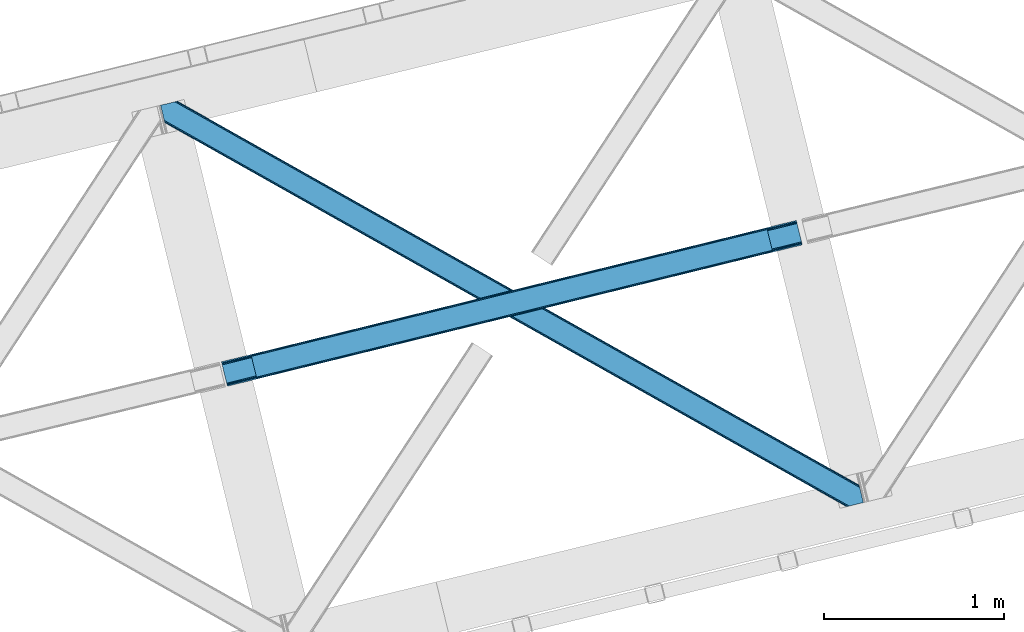
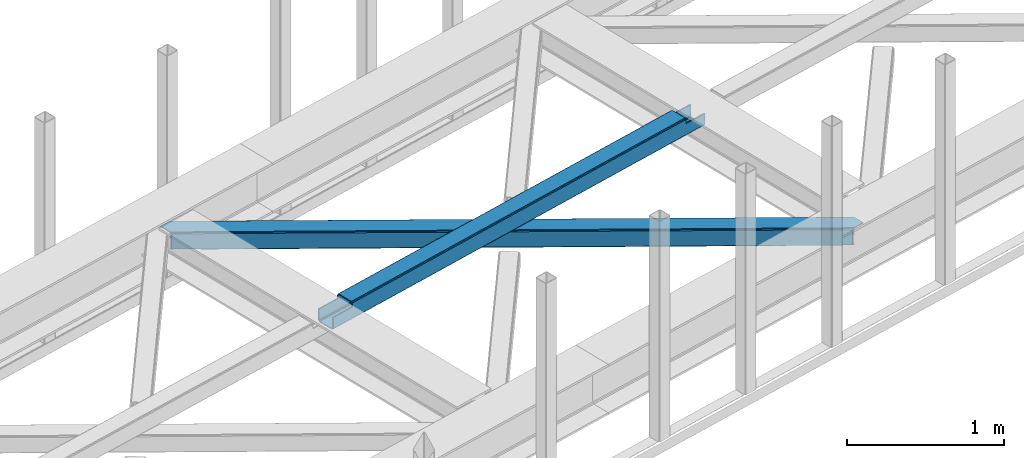
# One storey, part 30 of 67: 1 beam, 1 member.
"""IFC4 building model written with IfcOpenShell, lengths in millimetres."""

import ifcopenshell
import ifcopenshell.guid

model = None  # the IFC model being written
_history = None  # IfcOwnerHistory: only IFC2X3 demands one
_inside = {}  # id of a spatial element -> (the spatial element, [elements in it])
_under = {}  # id of a project, library or spatial element -> (it, [spatial elements below it])
_declared = {}  # id of a project -> (the project, [libraries it declares])
_typed = {}  # id of a type object -> (the type object, [elements of that type])
_made_of = {}  # id of a material, layer set ... -> (it, [elements and type objects made of it])


def new_model(schema):
    """Start an empty IFC model of exactly this schema.

    Asked for "IFC4X3", IfcOpenShell would pick the latest addendum, in which some entities
    have other attributes; the version numbers below select the first issue.
    IFC2X3 requires an IfcOwnerHistory on every rooted entity: one is made here for all.
    """
    global model, _history
    if schema == "IFC4X3":
        model = ifcopenshell.file(schema_version=(4, 3, 0, 0))
    else:
        model = ifcopenshell.file(schema=schema)
    _inside.clear()
    _under.clear()
    _declared.clear()
    _typed.clear()
    _made_of.clear()
    _history = None
    if model.schema == "IFC2X3":
        org = make("IfcOrganization", Name="unknown")
        user = make(
            "IfcPersonAndOrganization",
            ThePerson=make("IfcPerson", FamilyName="unknown"),
            TheOrganization=org,
        )
        app = make(
            "IfcApplication",
            ApplicationDeveloper=org,
            Version="unknown",
            ApplicationFullName="unknown",
            ApplicationIdentifier="unknown",
        )
        _history = make(
            "IfcOwnerHistory",
            OwningUser=user,
            OwningApplication=app,
            ChangeAction="ADDED",
            CreationDate=0,
        )
    return model


def make(cls, **values):
    """One entity of the class cls with the attributes given. An attribute that is None is left unset."""
    return model.create_entity(
        cls, **{name: value for name, value in values.items() if value is not None}
    )


def entity(cls, *values):
    """Any entity or typed value of the class cls, its attributes in the order of the schema. None: left unset."""
    e = model.create_entity(cls)
    for i, value in enumerate(values):
        if value is not None:
            e[i] = value
    return e


def rooted(cls, **values):
    """An entity with a GlobalId (a new one), such as an element, a storey or a relation."""
    return make(cls, GlobalId=ifcopenshell.guid.new(), OwnerHistory=_history, **values)


def si_unit(unit_type, name, prefix=None):
    """IfcSIUnit, for example si_unit("LENGTHUNIT", "METRE", prefix="MILLI")."""
    return make("IfcSIUnit", UnitType=unit_type, Prefix=prefix, Name=name)


def converted_unit(unit_type, name, factor, base, dimensions=None, offset=None):
    """IfcConversionBasedUnit, such as the inch: factor (a typed value) times the base unit."""
    return make(
        "IfcConversionBasedUnit"
        if offset is None
        else "IfcConversionBasedUnitWithOffset",
        ConversionOffset=offset,
        Dimensions=None
        if dimensions is None
        else entity("IfcDimensionalExponents", *dimensions),
        UnitType=unit_type,
        Name=name,
        ConversionFactor=make(
            "IfcMeasureWithUnit", ValueComponent=factor, UnitComponent=base
        ),
    )


def derived_unit(unit_type, elements):
    """IfcDerivedUnit: a product of units, each with its exponent."""
    return make(
        "IfcDerivedUnit",
        Elements=[
            make("IfcDerivedUnitElement", Unit=unit, Exponent=power)
            for unit, power in elements
        ],
        UnitType=unit_type,
    )


def assignment(units):
    """IfcUnitAssignment: the units of a project."""
    return None if units is None else make("IfcUnitAssignment", Units=units)


def point(xyz):
    """IfcCartesianPoint."""
    return None if xyz is None else make("IfcCartesianPoint", Coordinates=xyz)


def direction(xyz):
    """IfcDirection."""
    return None if xyz is None else make("IfcDirection", DirectionRatios=xyz)


def frame(location, z_axis=None, x_axis=None):
    """IfcAxis2Placement3D, a coordinate frame: its origin and axes. An axis left out is left unset."""
    return make(
        "IfcAxis2Placement3D",
        Location=point(location),
        Axis=direction(z_axis),
        RefDirection=direction(x_axis),
    )


def origin():
    """The frame at (0, 0, 0) with its axes left unset."""
    return frame((0.0, 0.0, 0.0))


def place(relative_to, where):
    """IfcLocalPlacement: puts the frame where relative to a parent placement (None: the world)."""
    return make(
        "IfcLocalPlacement", PlacementRelTo=relative_to, RelativePlacement=where
    )


def context(
    kind, dimensions, precision=None, world=None, true_north=None, identifier=None
):
    """IfcGeometricRepresentationContext, for example the 3D "Model" context."""
    return make(
        "IfcGeometricRepresentationContext",
        ContextIdentifier=identifier,
        ContextType=kind,
        CoordinateSpaceDimension=dimensions,
        Precision=precision,
        WorldCoordinateSystem=world,
        TrueNorth=true_north,
    )


def subcontext(parent, identifier, kind, view, scale=None):
    """IfcGeometricRepresentationSubContext, for example "Body" below "Model"."""
    return make(
        "IfcGeometricRepresentationSubContext",
        ContextIdentifier=identifier,
        ContextType=kind,
        ParentContext=parent,
        TargetScale=scale,
        TargetView=view,
    )


def project(units=None, contexts=None):
    """IfcProject with its units and contexts."""
    return rooted(
        "IfcProject",
        Name="project",
        RepresentationContexts=contexts,
        UnitsInContext=assignment(units),
    )


def spatial(cls, under=None, at=None, **own):
    """A site, building, storey or space (cls), placed at a placement, below another one or the project."""
    s = rooted(cls, ObjectPlacement=at, **own)
    if under is not None:
        _under.setdefault(under.id(), (under, []))[1].append(s)
    return s


def point_list(points):
    """IfcCartesianPointList2D or 3D."""
    cls = (
        "IfcCartesianPointList2D" if len(points[0]) == 2 else "IfcCartesianPointList3D"
    )
    return make(cls, CoordList=points)


def triangles(points, corners, closed=None, point_numbers=None):
    """IfcTriangulatedFaceSet: each triangle names its three corners, points numbered from 1."""
    return make(
        "IfcTriangulatedFaceSet",
        Coordinates=point_list(points),
        Closed=closed,
        CoordIndex=corners,
        PnIndex=point_numbers,
    )


def polygons(points, faces, closed=None, point_numbers=None):
    """IfcPolygonalFaceSet: a face is its outer loop, then its inner loops; points numbered from 1."""
    made = []
    for loops in faces:
        if len(loops) == 1:
            made.append(make("IfcIndexedPolygonalFace", CoordIndex=loops[0]))
        else:
            made.append(
                make(
                    "IfcIndexedPolygonalFaceWithVoids",
                    CoordIndex=loops[0],
                    InnerCoordIndices=loops[1:],
                )
            )
    return make(
        "IfcPolygonalFaceSet",
        Coordinates=point_list(points),
        Closed=closed,
        Faces=made,
        PnIndex=point_numbers,
    )


def shape(context_of_items, identifier, shape_type, items):
    """IfcShapeRepresentation: the items that make up one representation, for example the "Body"."""
    return make(
        "IfcShapeRepresentation",
        ContextOfItems=context_of_items,
        RepresentationIdentifier=identifier,
        RepresentationType=shape_type,
        Items=items,
    )


def material(Name=None, Category=None):
    """IfcMaterial."""
    return make("IfcMaterial", Name=Name, Category=Category)


def made_of(thing, what):
    """Note that an element or type object is made of a material, layer set ...; save() writes the relation."""
    if what is not None:
        _made_of.setdefault(what.id(), (what, []))[1].append(thing)
    return thing


def type_object(cls, material=None, **own):
    """A type object (cls), such as IfcWallType, which elements share."""
    return made_of(rooted(cls, **own), material)


def element(
    cls,
    number,
    at=None,
    inside=None,
    cuts=None,
    type_object=None,
    material=None,
    context=None,
    identifier="Body",
    shape_type=None,
    held_by="IfcProductDefinitionShape",
    body=None,
    shapes=None,
    **own,
):
    """One element of the class cls, such as IfcWall. Its Tag is "e" and its number.

    at: its placement. inside: the storey or other place that contains it. cuts: it is an
    opening in that element (IfcRelVoidsElement). A single representation is given by context,
    identifier, shape_type and body (its items); several are given by shapes. held_by: the class
    of the entity that holds the representations. save() writes the other relations.
    """
    e = rooted(cls, Tag="e%d" % number, ObjectPlacement=at, **own)
    if body is not None:
        shapes = [shape(context, identifier, shape_type, body)]
    if shapes is not None:
        e.Representation = make(held_by, Representations=shapes)
    if inside is not None:
        _inside.setdefault(inside.id(), (inside, []))[1].append(e)
    if cuts is not None:
        rooted(
            "IfcRelVoidsElement", RelatingBuildingElement=cuts, RelatedOpeningElement=e
        )
    if type_object is not None:
        _typed.setdefault(type_object.id(), (type_object, []))[1].append(e)
    return made_of(e, material)


def aggregate(whole, parts):
    """IfcRelAggregates: a whole, such as a stair, and the parts it consists of."""
    return rooted("IfcRelAggregates", RelatingObject=whole, RelatedObjects=parts)


def save(model, path):
    """Write the relations noted so far, then the file.

    IfcRelAggregates (storeys below a building ...), IfcRelContainedInSpatialStructure (elements
    in a storey), IfcRelDefinesByType, IfcRelAssociatesMaterial and IfcRelDeclares: one each for
    every whole, place, type object, material and project.
    """
    for whole, parts in _under.values():
        aggregate(whole, parts)
    for where, things in _inside.values():
        rooted(
            "IfcRelContainedInSpatialStructure",
            RelatedElements=things,
            RelatingStructure=where,
        )
    for kind, things in _typed.values():
        rooted("IfcRelDefinesByType", RelatedObjects=things, RelatingType=kind)
    for what, things in _made_of.values():
        rooted("IfcRelAssociatesMaterial", RelatedObjects=things, RelatingMaterial=what)
    for by, libraries in _declared.values():
        rooted("IfcRelDeclares", RelatingContext=by, RelatedDefinitions=libraries)
    model.write(path)


model = new_model("IFC4")

# Units and contexts
model_context = context("Model", 3, precision=0.01, world=origin(), true_north=direction((6.12303176911189e-17, 1.0)))
plan_context = context("Plan", 3, precision=0.01, world=origin(), true_north=direction((6.12303176911189e-17, 1.0)))
body_context = subcontext(model_context, "Body", "Model", "MODEL_VIEW")
ifc_project = project(units=[si_unit("LENGTHUNIT", "METRE", prefix="MILLI"), si_unit("AREAUNIT", "SQUARE_METRE"), si_unit("VOLUMEUNIT", "CUBIC_METRE"), converted_unit("PLANEANGLEUNIT", "DEGREE", entity("IfcRatioMeasure", 0.0174532925199433), si_unit("PLANEANGLEUNIT", "RADIAN"), dimensions=[0, 0, 0, 0, 0, 0, 0]), si_unit("MASSUNIT", "GRAM", prefix="KILO"), derived_unit("MASSDENSITYUNIT", [(si_unit("MASSUNIT", "GRAM", prefix="KILO"), 1), (si_unit("LENGTHUNIT", "METRE"), -3)]), derived_unit("MOMENTOFINERTIAUNIT", [(si_unit("LENGTHUNIT", "METRE"), 4)]), si_unit("TIMEUNIT", "SECOND"), si_unit("FREQUENCYUNIT", "HERTZ"), si_unit("THERMODYNAMICTEMPERATUREUNIT", "DEGREE_CELSIUS"), derived_unit("THERMALTRANSMITTANCEUNIT", [(si_unit("MASSUNIT", "GRAM", prefix="KILO"), 1), (si_unit("THERMODYNAMICTEMPERATUREUNIT", "KELVIN"), -1), (si_unit("TIMEUNIT", "SECOND"), -3)]), derived_unit("VOLUMETRICFLOWRATEUNIT", [(si_unit("LENGTHUNIT", "METRE"), 3), (si_unit("TIMEUNIT", "SECOND"), -1)]), derived_unit("MASSFLOWRATEUNIT", [(si_unit("MASSUNIT", "GRAM", prefix="KILO"), 1), (si_unit("TIMEUNIT", "SECOND"), -1)]), derived_unit("ROTATIONALFREQUENCYUNIT", [(si_unit("TIMEUNIT", "SECOND"), -1)]), si_unit("ELECTRICCURRENTUNIT", "AMPERE"), si_unit("ELECTRICVOLTAGEUNIT", "VOLT"), si_unit("POWERUNIT", "WATT"), si_unit("FORCEUNIT", "NEWTON", prefix="KILO"), si_unit("ILLUMINANCEUNIT", "LUX"), si_unit("LUMINOUSFLUXUNIT", "LUMEN"), si_unit("LUMINOUSINTENSITYUNIT", "CANDELA"), derived_unit("USERDEFINED", [(si_unit("MASSUNIT", "GRAM", prefix="KILO"), -1), (si_unit("LENGTHUNIT", "METRE"), -2), (si_unit("TIMEUNIT", "SECOND"), 3), (si_unit("LUMINOUSFLUXUNIT", "LUMEN"), 1)]), derived_unit("LINEARVELOCITYUNIT", [(si_unit("LENGTHUNIT", "METRE"), 1), (si_unit("TIMEUNIT", "SECOND"), -1)]), si_unit("PRESSUREUNIT", "PASCAL"), derived_unit("USERDEFINED", [(si_unit("LENGTHUNIT", "METRE"), -2), (si_unit("MASSUNIT", "GRAM", prefix="KILO"), 1), (si_unit("TIMEUNIT", "SECOND"), -2)]), derived_unit("LINEARFORCEUNIT", [(si_unit("MASSUNIT", "GRAM", prefix="KILO"), 1), (si_unit("LENGTHUNIT", "METRE"), 1), (si_unit("TIMEUNIT", "SECOND"), -2), (si_unit("LENGTHUNIT", "METRE"), -1)]), derived_unit("PLANARFORCEUNIT", [(si_unit("MASSUNIT", "GRAM", prefix="KILO"), 1), (si_unit("LENGTHUNIT", "METRE"), 1), (si_unit("TIMEUNIT", "SECOND"), -2), (si_unit("LENGTHUNIT", "METRE"), -2)])], contexts=[model_context, plan_context])

# Site, building, storey
site_placement = place(None, origin())
site = spatial("IfcSite", under=ifc_project, at=site_placement, CompositionType="ELEMENT")
building_placement = place(site_placement, origin())
building = spatial("IfcBuilding", under=site, at=building_placement, CompositionType="ELEMENT")
storey_placement = place(building_placement, frame((0.0, 0.0, 19800.0)))
storey = spatial("IfcBuildingStorey", under=building, at=storey_placement, CompositionType="ELEMENT", Elevation=19800.0)

# Beam
ifc_material = material(Name="Metal painted (White)")
beam_type = type_object("IfcBeamType", PredefinedType="BEAM")
beam_placement = place(storey_placement, frame((-42582.6021568335, 8753.04752962358, 3967.02196725781)))
element("IfcBeam", 1, at=beam_placement, inside=storey, type_object=beam_type, material=ifc_material, ObjectType="Steel Beam", PredefinedType="BEAM", context=body_context, shape_type="Tessellation", body=[
    polygons([(195.608367476555, 47.1603367907862, 116.426112013184), (195.292888840642, 48.4545519431655, 123.123071565755), (3059.93715946748, 752.952673698146, 122.247211281438), (3060.2526381034, 751.658458545759, 115.550251728867), (194.394481695369, 52.1401648754784, 128.800478116566), (3059.03875232221, 756.63828663046, 127.92461783224), (193.049920384546, 57.6560744289323, 132.593997984055), (3057.69419101138, 762.154196183919, 131.718137699738), (191.463902179238, 64.1625333758854, 133.926102156763), (3056.10817280608, 768.660655130851, 133.050241872438), (169.91268263321, 152.573955618372, 133.926046892466), (3034.55695326005, 857.072077373337, 133.05018660814), (168.326664427911, 159.080414565288, 132.593934585632), (3032.97093505476, 863.578536320267, 131.718074301311), (166.982103117088, 164.596324118746, 128.800407822355), (3031.62637374393, 869.094445873725, 127.924547538033), (166.083695971823, 168.281937051061, 123.12299666394), (3030.72796659867, 872.78005880604, 122.247136379614), (165.768217335893, 169.576152203463, 116.426035493392), (3030.41248796274, 874.074273958432, 115.550175209066), (3028.75470184381, 880.875152592466, 100.498256633611), (3028.75470184381, 880.875152592468, 122.550171266493), (3029.07018047973, 879.580937440089, 129.24713243705), (3029.968587625, 875.895324507774, 134.924543595464), (3031.31314893582, 870.379414954318, 138.718070358737), (3032.89916714112, 863.872956007376, 140.050182665567), (3057.76595892501, 761.859776496813, 140.050246432065), (3059.3519771303, 755.353317549901, 138.718142259361), (3060.69653844113, 749.837407996445, 134.924622391867), (3061.59494558639, 746.151795064129, 129.247215841061), (3061.91042422235, 744.857579911637, 122.55025628849), (3061.91042422232, 744.857579911717, 100.498256633611), (3060.2526381034, 751.658458545755, 100.498256633611), (3030.41248796274, 874.074273958429, 100.498256633611), (165.768217335893, 169.576152203463, 101.478032742183), (195.608367476546, 47.1603367907873, 101.478032742183), (197.266153595643, 40.3594581560808, 101.478032742183), (197.266153595478, 40.3594581567511, 123.426116572816), (196.950674959548, 41.6536733091445, 130.123076125387), (196.052267814283, 45.3392862414595, 135.800482676189), (194.707706503452, 50.8551957949178, 139.594002543682), (193.121688298162, 57.361654741847, 140.926106716386), (168.254896514278, 159.374834252409, 140.926042949888), (166.668878308987, 165.881293199339, 139.593930643059), (165.324316998156, 171.397202752797, 135.800403879781), (164.425909852882, 175.082815685111, 130.122992721366), (164.110431216969, 176.377030837501, 123.426031550818), (164.110431216961, 176.377030837499, 101.478032742183), (3224.36306932035, 792.017916694966, 99.4982566336028), (3224.36306932034, 792.017916694964, 24.5000712229983), (31.4979362596031, 6.80087864157621, 25.4762844973403), (31.4979362596031, 6.80087864157838, 100.478032742175), (194.637299836219, 46.9215234289606, 100.478032742183), (1.65778611894061, 129.216694054251, 25.4762079775439), (3194.52291917968, 914.433732107637, 24.4999947032018), (3194.52291917969, 914.43373210764, 99.4982566336028), (3031.38355560307, 874.313087320258, 99.4982566336115), (1.65778611894061, 129.216694054253, 100.478032742179), (3226.02085543916, 785.217038061375, 17.5000751655718), (3226.02085543927, 785.217038060912, 99.4982566336028), (3062.88149186268, 745.096393273461, 99.4982566336071), (33.1557223796959, 2.71258215889247e-09, 100.478032742175), (33.1557223787603, 6.59790941881511e-09, 18.4762884399095), (3192.86513306077, 921.234610741677, 99.4982566336028), (3192.86513306076, 921.234610741675, 17.4999901435748), (1.73258740687743e-11, 136.017572688288, 18.4762034179168), (1.73258740687743e-11, 136.017572688289, 100.478032742175), (163.139363576634, 176.138217475671, 100.478032742183), (3061.22370574374, 751.897271907586, 99.4982566336028), (3029.72576948415, 881.113965954297, 99.4982566336071), (3194.83839781561, 913.139516955241, 17.8030351506349), (3195.73680496087, 909.453904022926, 12.1256285998286), (3197.0813662717, 903.93799446947, 8.33210873233546), (3198.66738447699, 897.43153552254, 7.00000455963569), (3220.21860402303, 809.020113280054, 7.00005982392856), (3221.80462222832, 802.513654333124, 8.33217213075803), (3223.14918353915, 796.997744779667, 12.1256988940357), (3224.04759068442, 793.31213184735, 17.8031100524503), (3225.70537680334, 786.511253213297, 10.8031139950195), (3224.80696965809, 790.19686614561, 5.12570283660054), (3223.46240834725, 795.712775699067, 1.33217607332724), (3221.87639014196, 802.219234646016, 6.37665021031353e-05), (3197.00959835807, 904.232414156576, 4.33146851719357e-12), (3195.42358015278, 910.738873103494, 1.3321041727041), (3194.07901884195, 916.254782656952, 5.12562404019723), (3193.18061169669, 919.940395589265, 10.8030305909992), (196.295085955143, 40.1206447949233, 100.478032742179), (164.797149695557, 169.337338841635, 100.478032742179), (27.3534709622775, 23.8030752266689, 7.97627309827059), (28.9394891675764, 17.2966162797201, 9.30838540509573), (30.2840504784081, 11.780706726263, 13.101912168369), (31.1824576236816, 8.09509379395009, 18.7793233267793), (1.97326475486207, 127.922478901843, 18.779248424964), (2.87167190013556, 124.236865969529, 13.1018418741663), (4.21623321095863, 118.72095641607, 9.30832200667315), (5.80225141624883, 112.214497469155, 7.97621783397339), (0.315478635930117, 134.723357535894, 11.7792438653456), (1.21388578120361, 131.037744603581, 6.10183731454358), (2.55844709203534, 125.521835050121, 2.30831744704612), (4.14446529732554, 119.015376103192, 0.976213274346355), (29.0112570812095, 17.0021965926294, 0.976277040844127), (30.5972752865084, 10.4957376456991, 2.3083893476736), (31.9418365973314, 4.97982809224191, 6.1019161109469), (32.8402437426049, 1.29421515992579, 11.7793272693615)], [[[1, 2, 3, 4]], [[2, 5, 6, 3]], [[5, 7, 8, 6]], [[7, 9, 10, 8]], [[11, 12, 10, 9]], [[11, 13, 14, 12]], [[13, 15, 16, 14]], [[15, 17, 18, 16]], [[17, 19, 20, 18]], [[21, 22, 23, 24, 25, 26, 27, 28, 29, 30, 31, 32, 33, 4, 3, 6, 8, 10, 12, 14, 16, 18, 20, 34]], [[35, 19, 17, 15, 13, 11, 9, 7, 5, 2, 1, 36, 37, 38, 39, 40, 41, 42, 43, 44, 45, 46, 47, 48]], [[42, 41, 28, 27]], [[41, 40, 29, 28]], [[40, 39, 30, 29]], [[39, 38, 31, 30]], [[27, 26, 43, 42]], [[47, 46, 23, 22]], [[46, 45, 24, 23]], [[45, 44, 25, 24]], [[44, 43, 26, 25]], [[33, 49, 50, 51, 52, 53, 1, 4]], [[54, 55, 56, 57, 20, 19, 35, 58]], [[59, 60, 61, 31, 38, 37, 62, 63]], [[64, 65, 66, 67, 68, 47, 22, 21]], [[61, 60, 49, 69]], [[64, 70, 57, 56]], [[65, 64, 56, 55, 71, 72, 73, 74, 75, 76, 77, 78, 50, 49, 60, 59, 79, 80, 81, 82, 83, 84, 85, 86]], [[87, 53, 52, 62]], [[67, 58, 88, 68]], [[89, 90, 76, 75]], [[90, 91, 77, 76]], [[91, 92, 78, 77]], [[92, 51, 50, 78]], [[54, 93, 71, 55]], [[93, 94, 72, 71]], [[94, 95, 73, 72]], [[95, 96, 74, 73]], [[89, 75, 74, 96]], [[66, 97, 98, 99, 100, 101, 102, 103, 104, 63, 62, 52, 51, 92, 91, 90, 89, 96, 95, 94, 93, 54, 58, 67]], [[63, 104, 79, 59]], [[104, 103, 80, 79]], [[103, 102, 81, 80]], [[102, 101, 82, 81]], [[100, 99, 84, 83]], [[99, 98, 85, 84]], [[98, 97, 86, 85]], [[97, 66, 65, 86]], [[83, 82, 101, 100]]], closed=False),
])

# Member
member_type = type_object("IfcMemberType", PredefinedType="BRACE")
member_placement = place(storey_placement, frame((-42920.6313354492, 8083.99609680176, 3823.99987792968)))
element("IfcMember", 2, at=member_placement, inside=storey, type_object=member_type, ObjectType="Steel Horizontal Brace", PredefinedType="BRACE", context=body_context, shape_type="Tessellation", body=[
    triangles([(3809.33492431641, 0.0, 122.499499511719), (3811.23248291016, 0.462181091308594, 129.196765136719), (23.4543823242202, 2133.54884033203, 129.196765136719), (23.8869140625029, 2131.77569274902, 122.499499511719), (3816.62750244141, 1.7772171020506, 134.87548828125), (22.2265502929731, 2138.59504394531, 134.87548828125), (3824.70142822266, 3.74570159912037, 138.668280029298), (20.3848022460952, 2146.14690856934, 138.668280029298), (3834.22642822266, 6.06765289306622, 140.00075683594), (18.2128417968779, 2155.05566711426, 140.00075683594), (1916.9806640625, 1065.68204498291, 17.5012573242202), (2556.11374511719, 705.753433227539, 17.5012573242202), (3195.25147705078, 345.824821472168, 17.5012573242202), (3809.33492431641, 0.0, 17.5012573242202), (1277.84293212891, 1425.61123809814, 17.5012573242202), (638.709851074222, 1785.53984985352, 17.5012573242202), (23.8869140625029, 2131.77569274902, 17.5012573242202), (3885.455859375, 97.7219421386717, 140.00075683594), (3903.67335205078, 22.9956893920898, 140.00075683594), (69.4422729492217, 2246.71053771973, 140.00075683594), (0.0, 2229.7825012207, 140.00075683594), (3883.28854980469, 106.630700683593, 138.668280029298), (78.9672729492231, 2249.03248901367, 138.668280029298), (3881.44680175782, 114.183146667479, 134.87548828125), (87.0458496093779, 2251.00097351074, 134.87548828125), (3880.21431884766, 119.229931640624, 129.196765136719), (92.4408691406279, 2252.31600952148, 129.196765136719), (3879.78178710938, 121.001916503907, 122.499499511719), (94.3337768554702, 2252.77760925293, 122.499499511719), (3265.41463623047, 466.983123779297, 17.5012573242202), (3879.78178710938, 121.001916503907, 17.5012573242202), (2626.2908569336, 826.905921936035, 17.5012573242202), (1987.16707763672, 1186.82872009277, 17.5012573242202), (708.919519042975, 1906.67431640625, 17.5012573242202), (94.3337768554702, 2252.77760925293, 17.5012573242202), (1348.04329833985, 1546.75151824951, 17.5012573242202), (82.4833374023438, 2249.88941345215, 122.197192382813), (69.0143920898481, 2246.60589294434, 131.668707275392), (59.4893920898467, 2244.28394165039, 133.001184082033), (0.0, 2229.7825012207, 133.001184082033), (77.0883178710938, 2248.57437744141, 127.873590087893), (84.3808959960952, 2250.35101318359, 24.5008300781265), (77.0883178710938, 2248.57437744141, 12.1248413085959), (91.5804565429717, 2252.1067199707, 9.49942016601563), (82.4833374023438, 2249.88941345215, 17.8035644531265), (84.3808959960952, 2250.35101318359, 115.499926757813), (72.3072143554746, 2247.40933227539, 9.49942016601563), (92.0548461914077, 2252.22182922363, 10.8691040039084), (1983.48823242188, 1180.86745605469, 24.5008300781265), (3882.05141601563, 111.689694213866, 115.499926757813), (2626.78850097657, 818.593638610839, 24.5008300781265), (3270.08411865235, 456.319239807128, 24.5008300781265), (3882.05141601563, 111.689694213866, 24.5008300781265), (1340.18796386719, 1543.1418548584, 24.5008300781265), (696.8876953125, 1905.41625366211, 24.5008300781265), (3882.48394775391, 109.917709350586, 122.197192382813), (3883.71643066406, 104.871505737305, 127.873590087893), (3885.55817871094, 97.3190597534176, 131.668707275392), (3887.73013916016, 88.4097198486324, 133.001184082033), (3883.71643066406, 104.871505737305, 12.1248413085959), (3885.41400146484, 97.9004196166989, 8.52041015625218), (3880.58638916016, 117.703280639647, 8.52041015625218), (3903.67335205078, 22.9956893920898, 133.001184082033), (3882.48394775391, 109.917709350586, 17.8035644531265), (3880.37244873047, 118.591017150879, 10.9365417480476), (3844.18395996094, 8.49483032226544, 133.001184082033), (15.9432128906265, 2164.3678894043, 133.001184082033), (3834.65895996094, 6.17287902831958, 131.668707275392), (18.1151733398438, 2155.45913085938, 131.668707275392), (3826.58503417969, 4.20439453124982, 127.873590087893), (19.9569213867217, 2147.90610351562, 127.873590087893), (3821.19001464844, 2.88935852050781, 122.197192382813), (21.1847534179688, 2142.85989990234, 122.197192382813), (3819.29245605469, 2.42717742919922, 115.499926757813), (21.6172851562515, 2141.08791503906, 115.499926757813), (3208.50183105469, 346.396298217773, 24.5008300781265), (3819.29245605469, 2.42717742919922, 24.5008300781265), (2565.16435546875, 708.691044616698, 24.5008300781265), (1921.82687988281, 1070.98579101562, 24.5008300781265), (635.15192871094, 1795.5764465332, 24.5008300781265), (21.6172851562515, 2141.08791503906, 24.5008300781265), (1278.48940429688, 1433.28111877441, 24.5008300781265), (21.1847534179688, 2142.85989990234, 17.8035644531265), (23.2590454101592, 2134.35111694336, 9.49942016601563), (19.9569213867217, 2147.90610351562, 12.1248413085959), (23.3660156250044, 2133.91044616699, 10.8691040039084), (18.8686157226621, 2152.37676086426, 9.49942016601563), (3826.58503417969, 4.20439453124982, 12.1248413085959), (3812.86494140625, 0.859831237792605, 8.52041015625218), (3821.19001464844, 2.88935852050781, 17.8035644531265), (3834.0357421875, 6.02114410400372, 8.52041015625218), (3811.91616210938, 0.628450012206486, 10.9365417480476), (190.667431640628, 2055.62801513672, 9.49942016601563), (195.062512207034, 2037.60237121582, 9.49942016601563), (196.071752929689, 2037.66980895996, 8.49948120117188), (196.053149414067, 2037.42447509766, 8.8831787109375), (191.290649414063, 2056.67213745117, 8.85294799804615), (195.732238769531, 2037.48261108398, 9.08316650390771), (191.346459960943, 2055.82684020996, 9.20641479492406), (195.383422851563, 2037.54423522949, 9.29943237304906), (191.006945800786, 2055.72684631348, 9.35291748046802), (191.234838867189, 2057.51743469238, 8.49948120117188), (150.916369628911, 2218.69131774902, 9.49942016601563), (155.311450195317, 2200.66567382813, 9.49942016601563), (151.251232910159, 2218.34947814941, 9.25757446289208), (155.809094238284, 2200.23779296875, 9.42500610351635), (151.604699707037, 2217.985546875, 8.99945068359375), (156.246276855469, 2199.30529174805, 9.11804809570458), (151.958166503908, 2217.62045288086, 8.74132690429906), (156.692761230472, 2198.36465148926, 8.80643920898365), (152.293029785156, 2217.27977600098, 8.49948120117188), (157.129943847656, 2197.43215026855, 8.49948120117188), (3713.61518554688, 194.650328063964, 8.52041015625218), (3708.78757324219, 214.453189086913, 8.52041015625218), (3713.26636962891, 194.529986572265, 8.40181274414135), (3708.39689941407, 214.57120513916, 8.37390747070458), (3713.06173095704, 194.460804748534, 8.3320495605476), (3708.00157470704, 214.689802551269, 8.22740478515698), (3707.90390625, 214.478187561035, 7.87393798828271), (3713.112890625, 193.950370788574, 8.19484863281468), (3707.80623779297, 214.266572570801, 7.52047119140843), (3713.23846435547, 192.706260681152, 7.85765991211156), (3713.36403808594, 191.465638732911, 7.52047119140843), (3264.7635131836, 465.822729492187, 10.8039916992202), (3262.9031616211, 462.51711730957, 5.12526855468968), (3260.11728515625, 457.57032623291, 1.33247680664135), (3708.57828369141, 211.088859558105, 5.59500732422021), (708.2683959961, 1905.51392211914, 10.8039916992202), (706.40339355469, 1902.20830993652, 5.12526855468968), (153.144140625001, 2213.77533874512, 5.12526855468968), (703.61751708985, 1897.2609375, 1.33247680664135), (154.985888671879, 2206.22347412109, 1.33247680664135), (700.333996582034, 1891.42524719238, 0.0), (157.157849121097, 2197.31471557617, 0.0), (3710.29445800782, 204.05207977295, 1.33247680664135), (3712.46641845704, 195.143321228026, 0.0), (3256.82911376953, 451.735217285155, 0.0), (2625.63973388672, 825.744946289062, 10.8039916992202), (1986.51595458985, 1185.6677444458, 10.8039916992202), (1347.38752441407, 1545.59054260254, 10.8039916992202), (2623.77938232422, 822.439915466308, 5.12526855468968), (1984.65560302735, 1182.36271362305, 5.12526855468968), (1345.52717285157, 1542.28493041992, 5.12526855468968), (2620.98885498047, 817.492543029784, 1.33247680664135), (1981.8697265625, 1177.41534118652, 1.33247680664135), (1342.74129638672, 1537.33813934326, 1.33247680664135), (2617.70533447266, 811.657434082032, 0.0), (1978.58155517578, 1171.58023223877, 0.0), (1339.45777587891, 1531.50303039551, 0.0), (3746.51550292969, 55.464056396484, 0.0), (3203.83699951172, 361.072727966308, 0.0), (2564.69926757813, 721.001921081543, 0.0), (1925.56618652344, 1080.93053283691, 0.0), (1286.43310546875, 1440.85914459228, 0.0), (647.295373535162, 1800.78775634766, 0.0), (191.206933593756, 2057.63486938476, 0.0), (3195.90260009766, 346.985215759278, 10.8039916992202), (639.360974121097, 1786.70024414062, 10.8039916992202), (641.225976562506, 1790.00585632324, 5.12526855468968), (195.220642089844, 2041.17308349609, 5.12526855468968), (3197.76295166016, 350.290827941893, 5.12526855468968), (3200.548828125, 355.237619018555, 1.33247680664135), (3748.68746337891, 46.5552978515625, 1.33247680664135), (3752.58024902344, 34.810665893554, 8.52041015625218), (3750.40363769532, 39.5190994262693, 5.59500732422021), (3751.17568359376, 36.3408050537109, 7.52047119140843), (3752.23608398438, 35.1809921264648, 8.278564453125), (644.011853027347, 1794.95206604004, 1.33247680664135), (193.378894042973, 2048.72611083984, 1.33247680664135), (2561.41574707031, 715.166812133788, 1.33247680664135), (1922.27801513672, 1075.0948425293, 1.33247680664135), (1283.14493408203, 1435.02403564453, 1.33247680664135), (2558.62987060547, 710.219439697265, 5.12526855468968), (1919.49678955079, 1070.1486328125, 5.12526855468968), (1280.35905761719, 1430.07666320801, 5.12526855468968), (2556.76951904297, 706.914408874511, 10.8039916992202), (1917.63178710938, 1066.84243927002, 10.8039916992202), (1278.49870605469, 1426.77163238525, 10.8039916992202), (3745.61788330079, 59.1423202514643, 7.52047119140843), (3746.13413085938, 57.3435928344725, 7.90416870117406), (3746.6689819336, 56.4360900878901, 8.10880737304615), (3747.30150146485, 55.3774337768555, 8.34832763671875), (3747.75263671875, 54.6135269165034, 8.52041015625218), (3211.01795654297, 350.8623046875, 12.1248413085959), (3217.08735351563, 361.644786071776, 6.99957275390625), (3213.79918212891, 355.80909576416, 8.3320495605476), (3744.24587402344, 64.7762786865233, 6.99957275390625), (643.742102050783, 1810.82435302734, 6.99957275390625), (188.937304687504, 2066.94709167481, 6.99957275390625), (637.668054199225, 1800.04245300293, 12.1248413085959), (640.453930664065, 1804.98866271973, 8.3320495605476), (635.807702636725, 1796.73684082031, 17.8035644531265), (3209.15295410156, 347.556692504882, 17.8035644531265), (2565.81547851563, 709.851438903808, 17.8035644531265), (1922.4826538086, 1072.1467666626, 17.8035644531265), (1279.14517822266, 1434.44209442139, 17.8035644531265), (2567.68048095703, 713.157632446289, 12.1248413085959), (1924.3430053711, 1075.45237884522, 12.1248413085959), (1281.00552978516, 1437.74712524414, 12.1248413085959), (2570.46635742188, 718.104423522949, 8.3320495605476), (1927.12888183594, 1080.39916992188, 8.3320495605476), (1283.79140625001, 1442.6939163208, 8.3320495605476), (2573.74987792969, 723.939532470702, 6.99957275390625), (1930.41240234375, 1086.23427886963, 6.99957275390625), (1287.07492675781, 1448.52960662842, 6.99957275390625), (694.371569824223, 1900.95024719238, 12.1248413085959), (691.585693359375, 1896.00287475586, 8.3320495605476), (157.264819335942, 2196.88567199707, 8.41343994140698), (159.427478027348, 2188.00249328613, 6.99957275390625), (3261.49859619141, 441.071333312988, 6.99957275390625), (3264.78676757813, 446.906442260743, 8.3320495605476), (3714.73604736329, 185.831680297852, 6.99957275390625), (3267.57264404297, 451.853814697266, 12.1248413085959), (688.302172851567, 1890.16718444824, 6.99957275390625), (696.236572265625, 1904.25469665527, 17.8035644531265), (3269.43299560547, 455.15884552002, 17.8035644531265), (2621.48649902344, 809.18025970459, 8.3320495605476), (2618.19832763672, 803.345150756835, 6.99957275390625), (1978.18623046875, 1171.4546585083, 8.3320495605476), (1974.90270996094, 1165.61954956055, 6.99957275390625), (1331.59779052735, 1527.89336700439, 6.99957275390625), (1334.88596191406, 1533.72847595215, 8.3320495605476), (2624.27237548828, 814.127632141113, 12.1248413085959), (1980.97210693359, 1176.40203094482, 12.1248413085959), (1337.67183837891, 1538.67584838867, 12.1248413085959), (2626.13272705078, 817.432662963867, 17.8035644531265), (1982.83245849609, 1179.70706176758, 17.8035644531265), (1339.53218994141, 1541.98087921143, 17.8035644531265)], [[1, 2, 3], [3, 4, 1], [2, 5, 6], [6, 3, 2], [5, 7, 8], [8, 6, 5], [7, 9, 10], [10, 8, 7], [11, 1, 4], [1, 12, 13], [11, 12, 1], [13, 14, 1], [15, 4, 16], [4, 15, 11], [17, 16, 4], [9, 18, 10], [9, 19, 18], [20, 10, 18], [21, 10, 20], [18, 22, 23], [23, 20, 18], [22, 24, 25], [25, 23, 22], [24, 26, 27], [27, 25, 24], [26, 28, 29], [29, 27, 26], [30, 28, 31], [28, 30, 32], [28, 33, 29], [33, 28, 32], [34, 35, 29], [36, 29, 33], [29, 36, 34], [37, 29, 27], [38, 23, 20], [21, 39, 20], [39, 21, 40], [39, 38, 20], [41, 23, 38], [41, 37, 25], [25, 23, 41], [27, 25, 37], [42, 35, 29], [43, 44, 45], [37, 46, 29], [43, 47, 44], [42, 45, 35], [46, 42, 29], [48, 35, 45], [45, 44, 48], [49, 50, 46], [50, 51, 52], [49, 51, 50], [52, 53, 50], [54, 46, 55], [46, 54, 49], [42, 55, 46], [50, 56, 46], [37, 46, 56], [56, 57, 37], [41, 37, 57], [57, 58, 41], [38, 41, 58], [58, 59, 38], [39, 38, 59], [57, 24, 22], [60, 61, 62], [24, 57, 56], [58, 57, 22], [58, 18, 59], [19, 59, 18], [59, 19, 63], [58, 22, 18], [31, 28, 53], [62, 64, 60], [64, 31, 53], [65, 64, 62], [65, 31, 64], [28, 50, 53], [56, 26, 24], [28, 26, 56], [50, 28, 56], [59, 66, 67], [66, 59, 63], [67, 39, 59], [40, 39, 67], [66, 68, 67], [69, 67, 68], [68, 70, 69], [71, 69, 70], [70, 72, 71], [73, 71, 72], [72, 74, 73], [75, 73, 74], [76, 74, 77], [74, 76, 78], [74, 79, 75], [79, 74, 78], [80, 81, 75], [82, 75, 79], [75, 82, 80], [83, 84, 85], [81, 4, 17], [17, 86, 83], [86, 84, 83], [83, 81, 17], [75, 4, 81], [73, 71, 6], [3, 73, 6], [3, 4, 73], [75, 73, 4], [71, 8, 6], [69, 8, 71], [87, 85, 84], [69, 67, 10], [69, 10, 8], [67, 21, 10], [67, 40, 21], [72, 1, 2], [68, 7, 9], [19, 66, 9], [66, 19, 63], [66, 68, 9], [70, 7, 68], [70, 72, 5], [5, 7, 70], [2, 5, 72], [77, 14, 1], [88, 89, 90], [72, 74, 1], [88, 91, 89], [77, 90, 14], [74, 77, 1], [92, 14, 90], [90, 89, 92], [93, 94, 84], [84, 87, 93], [95, 96, 97], [96, 98, 99], [99, 98, 100], [101, 100, 94], [94, 93, 101], [100, 101, 99], [99, 97, 96], [97, 102, 95], [103, 104, 44], [47, 44, 104], [105, 106, 104], [107, 108, 106], [109, 110, 108], [111, 112, 110], [110, 109, 111], [108, 107, 109], [106, 105, 107], [104, 103, 105], [62, 61, 113], [113, 114, 62], [115, 116, 114], [117, 118, 116], [116, 115, 117], [119, 118, 120], [121, 119, 122], [122, 123, 121], [120, 122, 119], [117, 120, 118], [114, 113, 115], [124, 30, 31], [125, 124, 118], [118, 119, 125], [119, 121, 125], [124, 65, 114], [114, 116, 124], [116, 118, 124], [65, 62, 114], [126, 125, 127], [48, 128, 103], [128, 129, 130], [130, 111, 128], [128, 109, 107], [109, 128, 111], [128, 105, 103], [105, 128, 107], [128, 48, 35], [35, 34, 128], [103, 44, 48], [129, 131, 132], [132, 130, 129], [131, 133, 134], [134, 132, 131], [135, 136, 137], [137, 126, 135], [127, 135, 126], [121, 127, 125], [31, 65, 124], [30, 124, 138], [138, 32, 30], [32, 138, 139], [139, 33, 32], [33, 139, 36], [140, 36, 139], [36, 140, 34], [128, 34, 140], [124, 125, 138], [141, 138, 125], [138, 141, 139], [142, 139, 141], [139, 142, 143], [143, 140, 139], [140, 143, 129], [129, 128, 140], [125, 126, 141], [144, 141, 126], [141, 144, 145], [145, 142, 141], [142, 145, 146], [146, 143, 142], [143, 146, 129], [131, 129, 146], [126, 137, 147], [147, 144, 126], [144, 147, 148], [148, 145, 144], [145, 148, 146], [149, 146, 148], [146, 149, 133], [133, 131, 146], [136, 150, 151], [137, 151, 147], [151, 137, 136], [148, 152, 153], [152, 147, 151], [148, 147, 152], [133, 149, 154], [153, 149, 148], [149, 153, 154], [155, 133, 154], [156, 133, 155], [134, 133, 156], [157, 92, 14], [158, 16, 17], [159, 96, 95], [158, 86, 94], [94, 159, 158], [94, 98, 159], [86, 84, 94], [95, 160, 159], [161, 162, 163], [92, 157, 164], [157, 161, 165], [165, 166, 157], [167, 164, 157], [157, 166, 167], [164, 89, 92], [163, 165, 161], [150, 163, 162], [162, 151, 150], [155, 168, 169], [169, 156, 155], [168, 159, 160], [160, 169, 168], [17, 86, 158], [14, 13, 157], [151, 162, 152], [170, 152, 162], [152, 170, 153], [171, 153, 170], [153, 171, 172], [172, 154, 153], [154, 172, 168], [168, 155, 154], [162, 161, 173], [173, 170, 162], [170, 173, 174], [174, 171, 170], [171, 174, 175], [175, 172, 171], [172, 175, 168], [159, 168, 175], [161, 157, 176], [176, 173, 161], [173, 176, 177], [177, 174, 173], [174, 177, 175], [178, 175, 177], [175, 178, 159], [158, 159, 178], [157, 13, 176], [12, 176, 13], [176, 12, 11], [11, 177, 176], [177, 11, 15], [15, 178, 177], [178, 15, 16], [16, 158, 178], [166, 179, 180], [166, 180, 181], [167, 181, 182], [167, 182, 183], [91, 89, 183], [164, 183, 89], [184, 183, 182], [88, 91, 183], [183, 184, 88], [185, 180, 179], [182, 185, 186], [182, 181, 185], [180, 185, 181], [179, 187, 185], [188, 189, 102], [93, 85, 190], [93, 87, 85], [102, 190, 191], [190, 102, 97], [97, 99, 190], [80, 192, 81], [83, 81, 192], [192, 190, 83], [85, 83, 190], [102, 191, 188], [182, 186, 184], [90, 88, 184], [184, 193, 90], [77, 90, 193], [193, 76, 77], [76, 193, 78], [194, 78, 193], [78, 194, 79], [195, 79, 194], [79, 195, 82], [196, 82, 195], [82, 196, 80], [192, 80, 196], [193, 184, 197], [197, 194, 193], [194, 197, 198], [198, 195, 194], [195, 198, 199], [199, 196, 195], [196, 199, 190], [190, 192, 196], [184, 186, 200], [200, 197, 184], [197, 200, 201], [201, 198, 197], [198, 201, 202], [202, 199, 198], [199, 202, 190], [191, 190, 202], [186, 185, 200], [203, 200, 185], [200, 203, 201], [204, 201, 203], [201, 204, 202], [205, 202, 204], [202, 205, 191], [188, 191, 205], [206, 106, 108], [108, 207, 206], [108, 110, 207], [110, 208, 207], [104, 206, 43], [43, 47, 104], [207, 208, 209], [210, 123, 122], [122, 211, 210], [122, 117, 211], [210, 212, 123], [213, 211, 117], [61, 60, 113], [213, 113, 60], [209, 214, 207], [206, 215, 45], [45, 43, 206], [215, 55, 42], [42, 45, 215], [64, 53, 216], [52, 216, 53], [60, 64, 213], [216, 213, 64], [210, 211, 217], [217, 218, 210], [218, 217, 219], [219, 220, 218], [220, 219, 221], [222, 221, 219], [221, 222, 214], [207, 214, 222], [211, 213, 223], [223, 217, 211], [217, 223, 224], [224, 219, 217], [219, 224, 225], [225, 222, 219], [222, 225, 207], [206, 207, 225], [213, 216, 223], [226, 223, 216], [223, 226, 224], [227, 224, 226], [224, 227, 228], [228, 225, 224], [225, 228, 215], [215, 206, 225], [216, 52, 51], [51, 226, 216], [226, 51, 49], [49, 227, 226], [227, 49, 228], [54, 228, 49], [228, 54, 215], [55, 215, 54], [209, 134, 189], [132, 208, 130], [208, 132, 134], [130, 208, 111], [134, 209, 208], [189, 134, 156], [169, 102, 156], [102, 169, 160], [156, 102, 189], [160, 95, 102], [136, 212, 187], [123, 127, 121], [136, 123, 212], [123, 135, 127], [123, 136, 135], [150, 136, 187], [179, 150, 187], [165, 179, 166], [179, 163, 150], [179, 165, 163], [203, 185, 210], [210, 218, 203], [218, 204, 203], [204, 218, 220], [185, 212, 210], [185, 187, 212], [214, 188, 221], [188, 214, 189], [209, 189, 214], [205, 221, 188], [220, 205, 204], [221, 205, 220]]),
])

save(model, "model.ifc")
